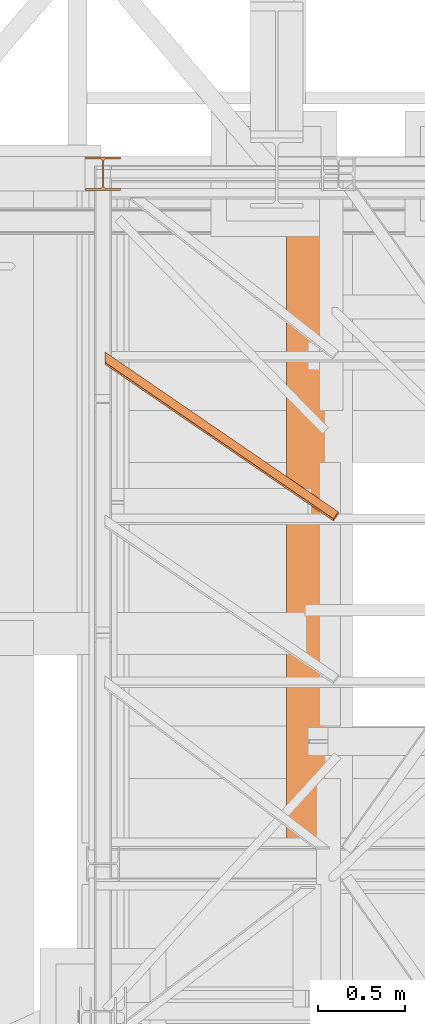
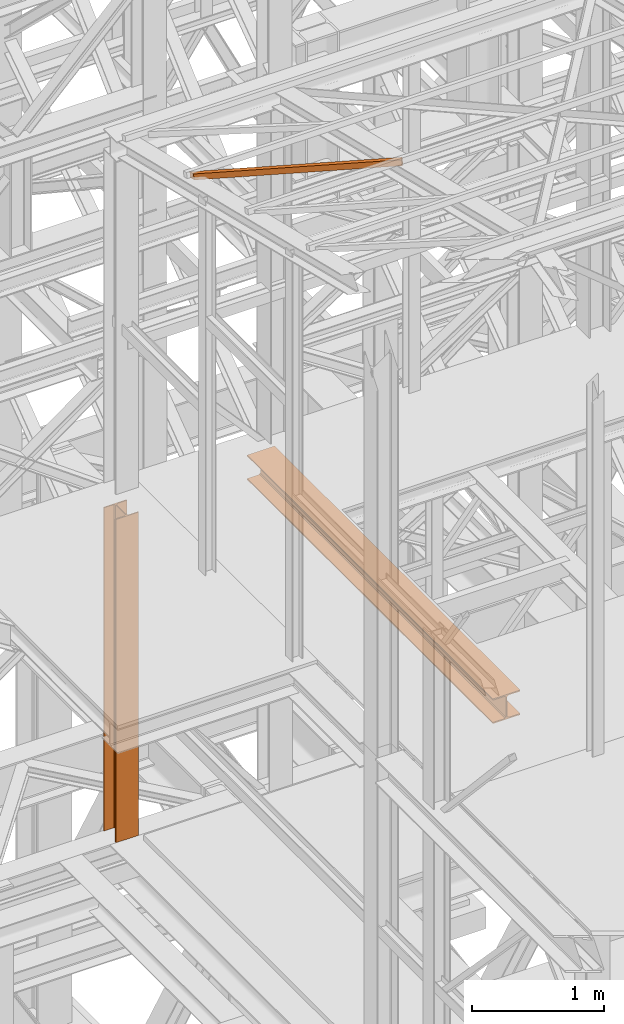
# One storey, part 34 of 208: 3 proxies.
"""IFC2X3 building model written with IfcOpenShell, lengths in millimetres."""

from ifc_helpers import new_model, entity, si_unit, converted_unit, frame, origin, origin_with_axes, place, context, subcontext, project, spatial, faceted_brep, element, save


model = new_model("IFC2X3")

# Units and contexts
model_context = context("Model", 3, precision=1e-05, world=origin())
plan_context = context("Plan", 3, precision=1e-05, world=origin())
body_context = subcontext(model_context, "Body", "Model", "MODEL_VIEW")
ifc_project = project(units=[si_unit("LENGTHUNIT", "METRE", prefix="MILLI"), converted_unit("PLANEANGLEUNIT", "DEGREE", entity("IfcPlaneAngleMeasure", 0.0174532925199433), si_unit("PLANEANGLEUNIT", "RADIAN"), dimensions=[0, 0, 0, 0, 0, 0, 0]), si_unit("AREAUNIT", "SQUARE_METRE"), si_unit("VOLUMEUNIT", "CUBIC_METRE")], contexts=[model_context, plan_context])

# Building, storey
building_placement = place(None, origin())
building = spatial("IfcBuilding", under=ifc_project, at=building_placement, CompositionType="COMPLEX")
storey_placement = place(building_placement, origin_with_axes())
storey = spatial("IfcBuildingStorey", under=building, at=storey_placement, Name="Geschoss", CompositionType="ELEMENT")

# Proxies
proxy_1_placement = place(storey_placement, frame((2248.254963760294, -21097.57438554952, 8254.989997913835), z_axis=(0.0, 0.0, 1.0), x_axis=(1.0, 0.0, 0.0)))
element("IfcBuildingElementProxy", 1, at=proxy_1_placement, inside=storey, context=body_context, shape_type="Brep", body=[
    faceted_brep([(240.0100095367443, 3735.009995231634, 230.0100041723217), (240.0100095367434, 0.01000000000203727, 230.0100041723217), (0.01000000000021828, 0.01000000000203727, 230.0100041723217), (0.01000000000112777, 3735.009995231634, 230.0100041723217), (0.01000000000112777, 3735.009995231634, 230.0100041723217), (0.01000000000021828, 0.01000000000203727, 230.0100041723217), (0.01000000000021828, 0.01000000000203727, 218.0100022053684), (0.01000000000112777, 3735.009995231634, 218.0100022053684), (0.01000000000112777, 3735.009995231634, 218.0100022053684), (0.01000000000021828, 0.01000000000203727, 218.0100022053684), (95.2600030398371, 0.01000000000203727, 218.0100022053684), (95.26000303983892, 3735.009995231634, 218.0100022053684), (95.26000303983892, 3735.009995231634, 218.0100022053684), (95.2600030398371, 0.01000000000203727, 218.0100022053684), (106.1284490099552, 0.01000000000203727, 215.8347008919682), (106.128449009957, 3735.009995231634, 215.8347008919682), (106.128449009957, 3735.009995231634, 215.8347008919682), (106.1284490099552, 0.01000000000203727, 215.8347008919682), (114.0846986493471, 0.01000000000203727, 207.8784493899311), (114.0846986493489, 3735.009995231634, 207.8784493899311), (114.0846986493489, 3735.009995231634, 207.8784493899311), (114.0846986493471, 0.01000000000203727, 207.8784493899311), (116.2600046193602, 0.01000000000203727, 197.0100043511357), (116.260004619362, 3735.009995231634, 197.0100043511357), (116.260004619362, 3735.009995231634, 197.0100043511357), (116.2600046193602, 0.01000000000203727, 197.0100043511357), (116.2600046193602, 0.01000000000203727, 33.00999982118628), (116.260004619362, 3735.009995231634, 33.00999982118628), (116.260004619362, 3735.009995231634, 33.00999982118628), (116.2600046193602, 0.01000000000203727, 33.00999982118628), (114.0846986493471, 0.01000000000203727, 22.14155478239081), (114.0846986493489, 3735.009995231634, 22.14155478239081), (114.0846986493489, 3735.009995231634, 22.14155478239081), (114.0846986493471, 0.01000000000203727, 22.14155478239081), (106.1284490099552, 0.01000000000203727, 14.18530328035376), (106.128449009957, 3735.009995231634, 14.18530328035376), (106.128449009957, 3735.009995231634, 14.18530328035376), (106.1284490099552, 0.01000000000203727, 14.18530328035376), (95.2600030398371, 0.01000000000203727, 12.0100019669535), (95.26000303983892, 3735.009995231634, 12.0100019669535), (95.26000303983892, 3735.009995231634, 12.0100019669535), (95.2600030398371, 0.01000000000203727, 12.0100019669535), (0.01000000000021828, 0.01000000000203727, 12.0100019669535), (0.01000000000203727, 3735.009995231634, 12.0100019669535), (0.01000000000203727, 3735.009995231634, 12.0100019669535), (0.01000000000021828, 0.01000000000203727, 12.0100019669535), (0.01000000000021828, 0.01000000000203727, 0.01000000000021828), (0.01000000000112777, 3735.009995231634, 0.01000000000021828), (0.01000000000112777, 3735.009995231634, 0.01000000000021828), (0.01000000000021828, 0.01000000000203727, 0.01000000000021828), (240.0100095367443, 0.01000000000203727, 0.00999999999839929), (240.0100095367443, 3735.009995231631, 0.01000000000021828), (240.0100095367443, 3735.009995231631, 0.01000000000021828), (240.0100095367443, 0.01000000000203727, 0.00999999999839929), (240.0100095367443, 0.01000000000203727, 12.0100019669535), (240.0100095367443, 3735.009995231634, 12.0100019669535), (240.0100095367443, 3735.009995231634, 12.0100019669535), (240.0100095367443, 0.01000000000203727, 12.0100019669535), (144.7600064969065, 0.01000000000203727, 12.0100019669535), (144.7600064969074, 3735.009995231634, 12.0100019669535), (144.7600064969074, 3735.009995231634, 12.0100019669535), (144.7600064969065, 0.01000000000203727, 12.0100019669535), (133.8915605267885, 0.01000000000203727, 14.18530328035376), (133.8915605267894, 3735.009995231634, 14.18530328035376), (133.8915605267894, 3735.009995231634, 14.18530328035376), (133.8915605267885, 0.01000000000203727, 14.18530328035376), (125.9353108873966, 0.01000000000203727, 22.14155478239081), (125.9353108873975, 3735.009995231631, 22.14155478239081), (125.9353108873975, 3735.009995231631, 22.14155478239081), (125.9353108873966, 0.01000000000203727, 22.14155478239081), (123.7600049173834, 0.01000000000203727, 33.00999982118628), (123.7600049173843, 3735.009995231634, 33.00999982118628), (123.7600049173843, 3735.009995231634, 33.00999982118628), (123.7600049173834, 0.01000000000203727, 33.00999982118628), (123.7600049173843, 0.01000000000203727, 197.0100043511357), (123.7600049173843, 3735.009995231634, 197.0100043511357), (123.7600049173843, 3735.009995231634, 197.0100043511357), (123.7600049173843, 0.01000000000203727, 197.0100043511357), (125.9353108873966, 0.01000000000203727, 207.8784493899311), (125.9353108873975, 3735.009995231634, 207.8784493899311), (125.9353108873975, 3735.009995231634, 207.8784493899311), (125.9353108873966, 0.01000000000203727, 207.8784493899311), (133.8915605267885, 0.01000000000203727, 215.8347008919682), (133.8915605267894, 3735.009995231631, 215.8347008919682), (133.8915605267894, 3735.009995231631, 215.8347008919682), (133.8915605267885, 0.01000000000203727, 215.8347008919682), (144.7600064969065, 0.01000000000203727, 218.0100022053684), (144.7600064969074, 3735.009995231634, 218.0100022053684), (144.7600064969074, 3735.009995231634, 218.0100022053684), (144.7600064969065, 0.01000000000203727, 218.0100022053684), (240.0100095367443, 0.01000000000203727, 218.0100022053684), (240.0100095367443, 3735.009995231634, 218.0100022053684), (240.0100095367443, 3735.009995231634, 218.0100022053684), (240.0100095367443, 0.01000000000203727, 218.0100022053684), (240.0100095367434, 0.01000000000203727, 230.0100041723217), (240.0100095367443, 3735.009995231634, 230.0100041723217), (0.01000000000112777, 3735.009995231634, 230.0100041723217), (0.01000000000112777, 3735.009995231634, 218.0100022053684), (95.26000303983892, 3735.009995231634, 218.0100022053684), (106.128449009957, 3735.009995231634, 215.8347008919682), (114.0846986493489, 3735.009995231634, 207.8784493899311), (116.260004619362, 3735.009995231634, 197.0100043511357), (116.260004619362, 3735.009995231634, 33.00999982118628), (114.0846986493489, 3735.009995231634, 22.14155478239081), (106.128449009957, 3735.009995231634, 14.18530328035376), (95.26000303983892, 3735.009995231634, 12.0100019669535), (0.01000000000203727, 3735.009995231634, 12.0100019669535), (0.01000000000112777, 3735.009995231634, 0.01000000000021828), (240.0100095367443, 3735.009995231631, 0.01000000000021828), (240.0100095367443, 3735.009995231634, 12.0100019669535), (144.7600064969074, 3735.009995231634, 12.0100019669535), (133.8915605267894, 3735.009995231634, 14.18530328035376), (125.9353108873975, 3735.009995231631, 22.14155478239081), (123.7600049173843, 3735.009995231634, 33.00999982118628), (123.7600049173843, 3735.009995231634, 197.0100043511357), (125.9353108873975, 3735.009995231634, 207.8784493899311), (133.8915605267894, 3735.009995231631, 215.8347008919682), (144.7600064969074, 3735.009995231634, 218.0100022053684), (240.0100095367443, 3735.009995231634, 218.0100022053684), (240.0100095367443, 3735.009995231634, 230.0100041723217), (240.0100095367434, 0.01000000000203727, 230.0100041723217), (240.0100095367443, 0.01000000000203727, 218.0100022053684), (144.7600064969065, 0.01000000000203727, 218.0100022053684), (133.8915605267885, 0.01000000000203727, 215.8347008919682), (125.9353108873966, 0.01000000000203727, 207.8784493899311), (123.7600049173843, 0.01000000000203727, 197.0100043511357), (123.7600049173834, 0.01000000000203727, 33.00999982118628), (125.9353108873966, 0.01000000000203727, 22.14155478239081), (133.8915605267885, 0.01000000000203727, 14.18530328035376), (144.7600064969065, 0.01000000000203727, 12.0100019669535), (240.0100095367443, 0.01000000000203727, 12.0100019669535), (240.0100095367443, 0.01000000000203727, 0.00999999999839929), (0.01000000000021828, 0.01000000000203727, 0.01000000000021828), (0.01000000000021828, 0.01000000000203727, 12.0100019669535), (95.2600030398371, 0.01000000000203727, 12.0100019669535), (106.1284490099552, 0.01000000000203727, 14.18530328035376), (114.0846986493471, 0.01000000000203727, 22.14155478239081), (116.2600046193602, 0.01000000000203727, 33.00999982118628), (116.2600046193602, 0.01000000000203727, 197.0100043511357), (114.0846986493471, 0.01000000000203727, 207.8784493899311), (106.1284490099552, 0.01000000000203727, 215.8347008919682), (95.2600030398371, 0.01000000000203727, 218.0100022053684), (0.01000000000021828, 0.01000000000203727, 218.0100022053684), (0.01000000000021828, 0.01000000000203727, 230.0100041723217)], [[[0, 1, 2, 3]], [[4, 5, 6, 7]], [[8, 9, 10, 11]], [[12, 13, 14, 15]], [[16, 17, 18, 19]], [[20, 21, 22, 23]], [[24, 25, 26, 27]], [[28, 29, 30, 31]], [[32, 33, 34, 35]], [[36, 37, 38, 39]], [[40, 41, 42, 43]], [[44, 45, 46, 47]], [[48, 49, 50, 51]], [[52, 53, 54, 55]], [[56, 57, 58, 59]], [[60, 61, 62, 63]], [[64, 65, 66, 67]], [[68, 69, 70, 71]], [[72, 73, 74, 75]], [[76, 77, 78, 79]], [[80, 81, 82, 83]], [[84, 85, 86, 87]], [[88, 89, 90, 91]], [[92, 93, 94, 95]], [[96, 97, 98, 99, 100, 101, 102, 103, 104, 105, 106, 107, 108, 109, 110, 111, 112, 113, 114, 115, 116, 117, 118, 119]], [[120, 121, 122, 123, 124, 125, 126, 127, 128, 129, 130, 131, 132, 133, 134, 135, 136, 137, 138, 139, 140, 141, 142, 143]]], orient=[[False], [False], [False], [False], [False], [False], [False], [False], [False], [False], [False], [False], [False], [False], [False], [False], [False], [False], [False], [False], [False], [False], [False], [False], [False], [False]]),
])
proxy_2_placement = place(storey_placement, frame((1209.754965757054, -19252.42762679125, 11987.74979641016), z_axis=(0.0, 0.0, 1.0), x_axis=(1.0, 0.0, 0.0)))
element("IfcBuildingElementProxy", 2, at=proxy_2_placement, inside=storey, context=body_context, shape_type="Brep", body=[
    faceted_brep([(1308.5389233782, 0.00999999999839929, 232.0521250666225), (1308.5389233782, 11.80406569683328, 280.6412186405796), (1337.349720073477, 51.51581022395476, 271.0019582749592), (1337.349720073477, 39.72174452711624, 222.4128647010039), (0.009999999999990905, 896.5242864318316, 14.44056628674844), (0.009999999999990905, 908.3183521286664, 63.02965986070558), (1308.5389233782, 11.80406569683328, 280.6412186405796), (1308.5389233782, 0.00999999999839929, 232.0521250666225), (0.009999999999990905, 955.9752131652676, 0.01000000000021828), (0.009999999999990905, 896.5242864318316, 14.44056628674844), (1308.5389233782, 0.00999999999839929, 232.0521250666225), (1337.349720073477, 39.72174452711624, 222.4128647010039), (0.009999999999990905, 967.7692788621025, 48.59909357395554), (0.009999999999990905, 955.9752131652676, 0.01000000000021828), (1337.349720073477, 39.72174452711624, 222.4128647010039), (1337.349720073477, 51.51581022395476, 271.0019582749592), (0.009999999999990905, 908.3183521286664, 63.02965986070558), (0.009999999999990905, 967.7692788621025, 48.59909357395554), (1337.349720073477, 51.51581022395476, 271.0019582749592), (1308.5389233782, 11.80406569683328, 280.6412186405796), (0.009999999999990905, 896.5242864318316, 14.44056628674844), (0.009999999999990905, 955.9752131652676, 0.01000000000021828), (0.009999999999990905, 967.7692788621025, 48.59909357395554), (0.009999999999990905, 908.3183521286664, 63.02965986070558)], [[[0, 1, 2, 3]], [[4, 5, 6, 7]], [[8, 9, 10, 11]], [[12, 13, 14, 15]], [[16, 17, 18, 19]], [[20, 21, 22, 23]]], orient=[[False], [False], [False], [False], [False], [False]]),
])
proxy_3_placement = place(storey_placement, frame((1098.25496703855, -17357.57438790132, 5284.990005364414), z_axis=(0.0, 0.0, 1.0), x_axis=(1.0, 0.0, 0.0)))
element("IfcBuildingElementProxy", 3, at=proxy_3_placement, inside=storey, context=body_context, shape_type="Brep", body=[
    faceted_brep([(0.0100000000009004, 190.0100125169738, 3000.009996721743), (200.0100029802331, 190.0100125169738, 3000.009996721743), (200.0100029802331, 180.0100146031364, 3000.009996721743), (121.2600035762796, 180.0100071525558, 3000.009996721743), (111.9441915473351, 178.1454621052726, 3000.009996721743), (105.1245498640844, 171.3258190250381, 3000.009996721743), (103.2600015571723, 162.0100079274162, 3000.009996721743), (103.2600015571723, 28.00999713897545, 3000.009996721743), (105.1245498640844, 18.69418604135353, 3000.009996721743), (111.9441915473351, 11.87454296111901, 3000.009996721743), (121.2600035762796, 10.00999791383583, 3000.009996721743), (200.0100029802331, 10.00999791383583, 3000.009996721743), (200.0100029802331, 0.00999999999839929, 3000.009996721743), (0.0100000000009004, 0.00999999999839929, 3000.009996721743), (0.0100000000009004, 10.00999791383583, 3000.009996721743), (78.75999940395445, 10.00999791383583, 3000.009996721743), (88.07581143289894, 11.87454296111901, 3000.009996721743), (94.89545311614961, 18.69418604135353, 3000.009996721743), (96.7600014230618, 28.00999713897545, 3000.009996721743), (96.7600014230618, 162.0100079274162, 3000.009996721743), (94.89545311614961, 171.3258190250381, 3000.009996721743), (88.07581143289894, 178.1454621052726, 3000.009996721743), (78.75999940395445, 180.0100071525558, 3000.009996721743), (0.0100000000009004, 180.0100146031364, 3000.009996721743), (200.0100029802331, 190.0100125169738, 3000.009996721743), (0.0100000000009004, 190.0100125169738, 3000.009996721743), (0.009999999999990905, 190.0100125169738, 0.01000000000021828), (200.0100029802322, 190.0100125169738, 0.01000000000021828), (200.0100029802331, 180.0100146031364, 3000.009996721743), (200.0100029802331, 190.0100125169738, 3000.009996721743), (200.0100029802322, 190.0100125169738, 0.01000000000021828), (200.0100029802322, 180.0100146031364, 0.01000000000021828), (121.2600035762796, 180.0100071525558, 3000.009996721743), (200.0100029802331, 180.0100146031364, 3000.009996721743), (200.0100029802322, 180.0100146031364, 0.01000000000021828), (121.2600035762787, 180.0100071525558, 0.01000000000021828), (111.9441915473351, 178.1454621052726, 3000.009996721743), (121.2600035762796, 180.0100071525558, 3000.009996721743), (121.2600035762787, 180.0100071525558, 0.01000000000021828), (111.9441915473342, 178.1454621052726, 0.01000000000021828), (105.1245498640844, 171.3258190250381, 3000.009996721743), (111.9441915473351, 178.1454621052726, 3000.009996721743), (111.9441915473342, 178.1454621052726, 0.01000000000021828), (105.1245498640835, 171.3258190250381, 0.01000000000021828), (103.2600015571723, 162.0100079274162, 3000.009996721743), (105.1245498640844, 171.3258190250381, 3000.009996721743), (105.1245498640835, 171.3258190250381, 0.01000000000021828), (103.2600015571713, 162.0100079274162, 0.01000000000021828), (103.2600015571723, 28.00999713897545, 3000.009996721743), (103.2600015571723, 162.0100079274162, 3000.009996721743), (103.2600015571713, 162.0100079274162, 0.01000000000021828), (103.2600015571713, 28.00999713897545, 0.01000000000021828), (105.1245498640844, 18.69418604135353, 3000.009996721743), (103.2600015571723, 28.00999713897545, 3000.009996721743), (103.2600015571713, 28.00999713897545, 0.01000000000021828), (105.1245498640835, 18.69418604135353, 0.01000000000021828), (111.9441915473351, 11.87454296111901, 3000.009996721743), (105.1245498640844, 18.69418604135353, 3000.009996721743), (105.1245498640835, 18.69418604135353, 0.01000000000021828), (111.9441915473342, 11.87454296111901, 0.01000000000021828), (121.2600035762796, 10.00999791383583, 3000.009996721743), (111.9441915473351, 11.87454296111901, 3000.009996721743), (111.9441915473342, 11.87454296111901, 0.01000000000021828), (121.2600035762787, 10.00999791383583, 0.01000000000021828), (200.0100029802331, 10.00999791383583, 3000.009996721743), (121.2600035762796, 10.00999791383583, 3000.009996721743), (121.2600035762787, 10.00999791383583, 0.01000000000021828), (200.0100029802322, 10.00999791383583, 0.01000000000021828), (200.0100029802331, 0.00999999999839929, 3000.009996721743), (200.0100029802331, 10.00999791383583, 3000.009996721743), (200.0100029802322, 10.00999791383583, 0.01000000000021828), (200.0100029802322, 0.00999999999839929, 0.01000000000021828), (0.0100000000009004, 0.00999999999839929, 3000.009996721743), (200.0100029802331, 0.00999999999839929, 3000.009996721743), (200.0100029802322, 0.00999999999839929, 0.01000000000021828), (0.009999999999990905, 0.00999999999839929, 0.01000000000021828), (0.0100000000009004, 10.00999791383583, 3000.009996721743), (0.0100000000009004, 0.00999999999839929, 3000.009996721743), (0.009999999999990905, 0.00999999999839929, 0.01000000000021828), (0.009999999999990905, 10.00999791383583, 0.01000000000021828), (78.75999940395445, 10.00999791383583, 3000.009996721743), (0.0100000000009004, 10.00999791383583, 3000.009996721743), (0.009999999999990905, 10.00999791383583, 0.01000000000021828), (78.75999940395354, 10.00999791383583, 0.01000000000021828), (88.07581143289894, 11.87454296111901, 3000.009996721743), (78.75999940395445, 10.00999791383583, 3000.009996721743), (78.75999940395354, 10.00999791383583, 0.01000000000021828), (88.07581143289804, 11.87454296111901, 0.01000000000021828), (94.89545311614961, 18.69418604135353, 3000.009996721743), (88.07581143289894, 11.87454296111901, 3000.009996721743), (88.07581143289804, 11.87454296111901, 0.01000000000021828), (94.8954531161487, 18.69418604135353, 0.01000000000021828), (96.7600014230618, 28.00999713897545, 3000.009996721743), (94.89545311614961, 18.69418604135353, 3000.009996721743), (94.8954531161487, 18.69418604135353, 0.01000000000021828), (96.76000142306088, 28.00999713897545, 0.01000000000021828), (96.7600014230618, 162.0100079274162, 3000.009996721743), (96.7600014230618, 28.00999713897545, 3000.009996721743), (96.76000142306088, 28.00999713897545, 0.01000000000021828), (96.76000142306088, 162.0100079274162, 0.01000000000021828), (94.89545311614961, 171.3258190250381, 3000.009996721743), (96.7600014230618, 162.0100079274162, 3000.009996721743), (96.76000142306088, 162.0100079274162, 0.01000000000021828), (94.8954531161487, 171.3258190250381, 0.01000000000021828), (88.07581143289894, 178.1454621052726, 3000.009996721743), (94.89545311614961, 171.3258190250381, 3000.009996721743), (94.8954531161487, 171.3258190250381, 0.01000000000021828), (88.07581143289804, 178.1454621052726, 0.01000000000021828), (78.75999940395445, 180.0100071525558, 3000.009996721743), (88.07581143289894, 178.1454621052726, 3000.009996721743), (88.07581143289804, 178.1454621052726, 0.01000000000021828), (78.75999940395354, 180.0100071525558, 0.01000000000021828), (0.0100000000009004, 180.0100146031364, 3000.009996721743), (78.75999940395445, 180.0100071525558, 3000.009996721743), (78.75999940395354, 180.0100071525558, 0.01000000000021828), (0.009999999999990905, 180.0100146031364, 0.01000000000021828), (0.0100000000009004, 190.0100125169738, 3000.009996721743), (0.0100000000009004, 180.0100146031364, 3000.009996721743), (0.009999999999990905, 180.0100146031364, 0.01000000000021828), (0.009999999999990905, 190.0100125169738, 0.01000000000021828), (0.009999999999990905, 190.0100125169738, 0.01000000000021828), (0.009999999999990905, 180.0100146031364, 0.01000000000021828), (78.75999940395354, 180.0100071525558, 0.01000000000021828), (88.07581143289804, 178.1454621052726, 0.01000000000021828), (94.8954531161487, 171.3258190250381, 0.01000000000021828), (96.76000142306088, 162.0100079274162, 0.01000000000021828), (96.76000142306088, 28.00999713897545, 0.01000000000021828), (94.8954531161487, 18.69418604135353, 0.01000000000021828), (88.07581143289804, 11.87454296111901, 0.01000000000021828), (78.75999940395354, 10.00999791383583, 0.01000000000021828), (0.009999999999990905, 10.00999791383583, 0.01000000000021828), (0.009999999999990905, 0.00999999999839929, 0.01000000000021828), (200.0100029802322, 0.00999999999839929, 0.01000000000021828), (200.0100029802322, 10.00999791383583, 0.01000000000021828), (121.2600035762787, 10.00999791383583, 0.01000000000021828), (111.9441915473342, 11.87454296111901, 0.01000000000021828), (105.1245498640835, 18.69418604135353, 0.01000000000021828), (103.2600015571713, 28.00999713897545, 0.01000000000021828), (103.2600015571713, 162.0100079274162, 0.01000000000021828), (105.1245498640835, 171.3258190250381, 0.01000000000021828), (111.9441915473342, 178.1454621052726, 0.01000000000021828), (121.2600035762787, 180.0100071525558, 0.01000000000021828), (200.0100029802322, 180.0100146031364, 0.01000000000021828), (200.0100029802322, 190.0100125169738, 0.01000000000021828)], [[[0, 1, 2, 3, 4, 5, 6, 7, 8, 9, 10, 11, 12, 13, 14, 15, 16, 17, 18, 19, 20, 21, 22, 23]], [[24, 25, 26, 27]], [[28, 29, 30, 31]], [[32, 33, 34, 35]], [[36, 37, 38, 39]], [[40, 41, 42, 43]], [[44, 45, 46, 47]], [[48, 49, 50, 51]], [[52, 53, 54, 55]], [[56, 57, 58, 59]], [[60, 61, 62, 63]], [[64, 65, 66, 67]], [[68, 69, 70, 71]], [[72, 73, 74, 75]], [[76, 77, 78, 79]], [[80, 81, 82, 83]], [[84, 85, 86, 87]], [[88, 89, 90, 91]], [[92, 93, 94, 95]], [[96, 97, 98, 99]], [[100, 101, 102, 103]], [[104, 105, 106, 107]], [[108, 109, 110, 111]], [[112, 113, 114, 115]], [[116, 117, 118, 119]], [[120, 121, 122, 123, 124, 125, 126, 127, 128, 129, 130, 131, 132, 133, 134, 135, 136, 137, 138, 139, 140, 141, 142, 143]]], orient=[[False], [False], [False], [False], [False], [False], [False], [False], [False], [False], [False], [False], [False], [False], [False], [False], [False], [False], [False], [False], [False], [False], [False], [False], [False], [False]]),
])

save(model, "model.ifc")
